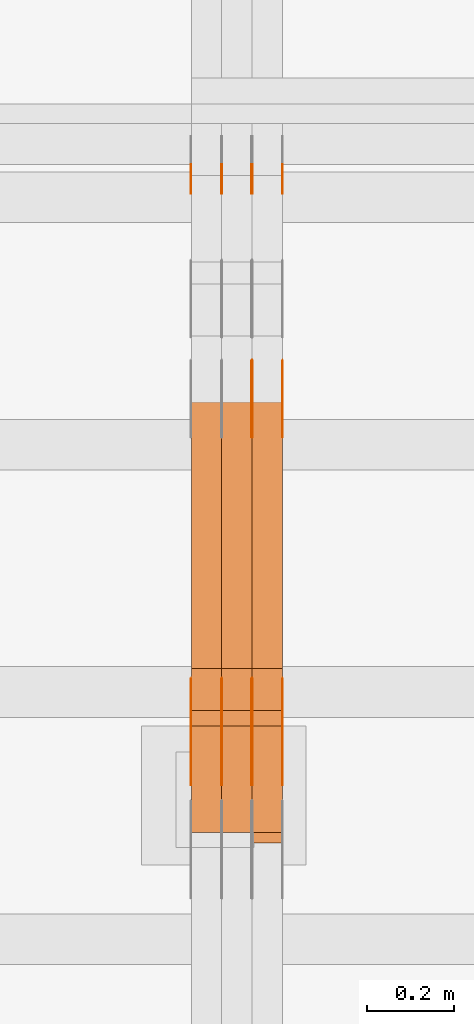
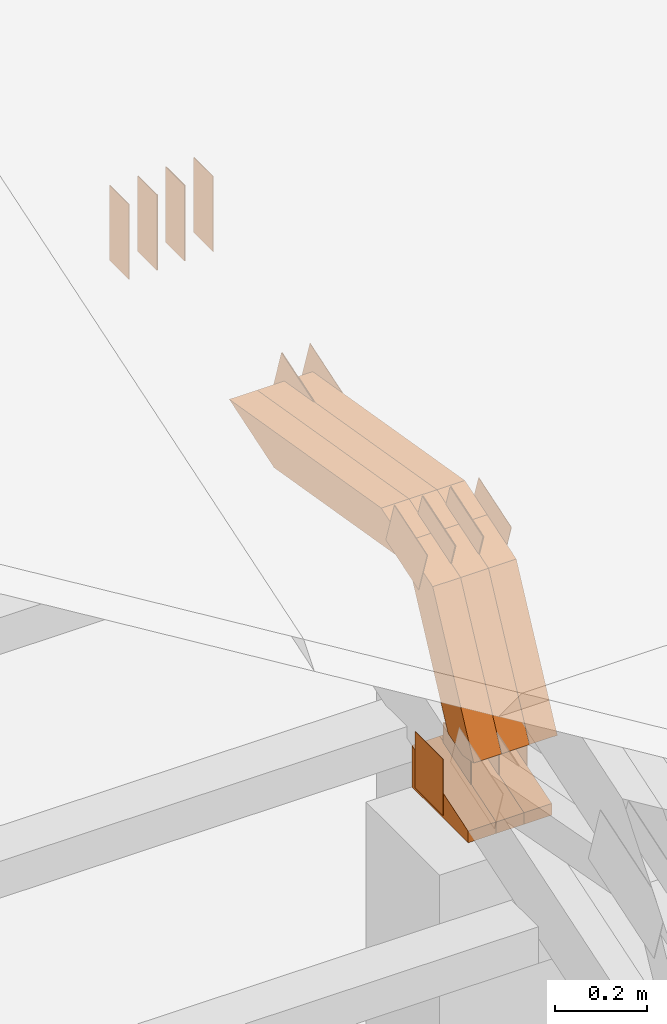
# One storey, part 159 of 385: 30 proxies.
"""IFC2X3 building model written with IfcOpenShell, lengths in millimetres."""

from ifc_helpers import new_model, entity, si_unit, converted_unit, derived_unit, direction, frame, frame_2d, origin, place, context, subcontext, project, spatial, polyline, rectangle, outline, extrude, source, transform, mapped, material, type_object, type_shapes, element, save


model = new_model("IFC2X3")

# Units and contexts
model_context = context("Model", 3, precision=0.01, world=origin(), true_north=direction((6.12303176911189e-17, 1.0)))
body_context = subcontext(model_context, "Body", "Model", "MODEL_VIEW")
ifc_project = project(units=[si_unit("LENGTHUNIT", "METRE", prefix="MILLI"), si_unit("AREAUNIT", "SQUARE_METRE"), si_unit("VOLUMEUNIT", "CUBIC_METRE"), converted_unit("PLANEANGLEUNIT", "DEGREE", entity("IfcRatioMeasure", 0.0174532925199433), si_unit("PLANEANGLEUNIT", "RADIAN"), dimensions=[0, 0, 0, 0, 0, 0, 0]), si_unit("MASSUNIT", "GRAM", prefix="KILO"), derived_unit("MASSDENSITYUNIT", [(si_unit("MASSUNIT", "GRAM", prefix="KILO"), 1), (si_unit("LENGTHUNIT", "METRE"), -3)]), si_unit("TIMEUNIT", "SECOND"), si_unit("FREQUENCYUNIT", "HERTZ"), si_unit("THERMODYNAMICTEMPERATUREUNIT", "DEGREE_CELSIUS"), derived_unit("THERMALTRANSMITTANCEUNIT", [(si_unit("MASSUNIT", "GRAM", prefix="KILO"), 1), (si_unit("THERMODYNAMICTEMPERATUREUNIT", "KELVIN"), -1), (si_unit("TIMEUNIT", "SECOND"), -3)]), derived_unit("VOLUMETRICFLOWRATEUNIT", [(si_unit("LENGTHUNIT", "METRE"), 3), (si_unit("TIMEUNIT", "SECOND"), -1)]), si_unit("ELECTRICCURRENTUNIT", "AMPERE"), si_unit("ELECTRICVOLTAGEUNIT", "VOLT"), si_unit("POWERUNIT", "WATT"), si_unit("FORCEUNIT", "NEWTON", prefix="KILO"), si_unit("ILLUMINANCEUNIT", "LUX"), si_unit("LUMINOUSFLUXUNIT", "LUMEN"), si_unit("LUMINOUSINTENSITYUNIT", "CANDELA"), derived_unit("USERDEFINED", [(si_unit("MASSUNIT", "GRAM", prefix="KILO"), -1), (si_unit("LENGTHUNIT", "METRE"), -2), (si_unit("TIMEUNIT", "SECOND"), 3), (si_unit("LUMINOUSFLUXUNIT", "LUMEN"), 1)]), derived_unit("LINEARVELOCITYUNIT", [(si_unit("LENGTHUNIT", "METRE"), 1), (si_unit("TIMEUNIT", "SECOND"), -1)]), si_unit("PRESSUREUNIT", "PASCAL"), derived_unit("USERDEFINED", [(si_unit("LENGTHUNIT", "METRE"), -2), (si_unit("MASSUNIT", "GRAM", prefix="KILO"), 1), (si_unit("TIMEUNIT", "SECOND"), -2)])], contexts=[model_context])

# Site, building, storey
site_placement = place(None, origin())
site = spatial("IfcSite", under=ifc_project, at=site_placement, CompositionType="ELEMENT")
building_placement = place(site_placement, origin())
building = spatial("IfcBuilding", under=site, at=building_placement, CompositionType="ELEMENT")
storey_placement = place(building_placement, origin())
storey = spatial("IfcBuildingStorey", under=building, at=storey_placement, Name="Default", CompositionType="ELEMENT", Elevation=0.0)

# Proxies
ifc_material_1 = material(Name="IfcSurfaceStyle #381300")
building_element_proxy_type_1 = type_object("IfcBuildingElementProxyType", PredefinedType="NOTDEFINED", material=ifc_material_1)
shared_shape_1 = source(origin(), body_context, "Body", "SweptSolid", [
    extrude(rectangle(XDim=200.0, YDim=84.0, at=frame_2d((0.0, -7.105427357601e-15), x_axis=(1.0, 0.0))), frame((100.0, 42.0, 0.0), z_axis=(0.0, 0.0, 1.0), x_axis=(-1.0, 0.0, 0.0)), (0.0, 0.0, 1.0), 1.3),
])
type_shapes(building_element_proxy_type_1, [shared_shape_1])
proxy_1_placement = place(building_placement, frame((30386.3, 13702.0, 3651.4150390625), z_axis=(-1.0, 0.0, 0.0), x_axis=(0.0, 0.0, -1.0)))
element("IfcBuildingElementProxy", 1, at=proxy_1_placement, inside=storey, type_object=building_element_proxy_type_1, material=ifc_material_1, context=body_context, shape_type="MappedRepresentation", body=[
    mapped(shared_shape_1, transform((0.0, 0.0, 0.0), scale=1.0)),
])
ifc_material_2 = material(Name="IfcSurfaceStyle #381243")
building_element_proxy_type_2 = type_object("IfcBuildingElementProxyType", PredefinedType="NOTDEFINED", material=ifc_material_2)
shared_shape_2 = source(origin(), body_context, "Body", "SweptSolid", [
    extrude(rectangle(XDim=200.0, YDim=84.0, at=frame_2d((0.0, -7.105427357601e-15), x_axis=(1.0, 0.0))), frame((100.0, 42.0, 0.0), z_axis=(0.0, 0.0, 1.0), x_axis=(-1.0, 0.0, 0.0)), (0.0, 0.0, 1.0), 1.3),
])
type_shapes(building_element_proxy_type_2, [shared_shape_2])
proxy_2_placement = place(building_placement, frame((30315.0, 13702.0, 3651.4150390625), z_axis=(-1.0, 0.0, 0.0), x_axis=(0.0, 0.0, -1.0)))
element("IfcBuildingElementProxy", 2, at=proxy_2_placement, inside=storey, type_object=building_element_proxy_type_2, material=ifc_material_2, context=body_context, shape_type="MappedRepresentation", body=[
    mapped(shared_shape_2, transform((0.0, 0.0, 0.0), scale=1.0)),
])
ifc_material_3 = material(Name="IfcSurfaceStyle #381186")
building_element_proxy_type_3 = type_object("IfcBuildingElementProxyType", PredefinedType="NOTDEFINED", material=ifc_material_3)
shared_shape_3 = source(origin(), body_context, "Body", "SweptSolid", [
    extrude(rectangle(XDim=200.0, YDim=84.0, at=frame_2d((0.0, -7.105427357601e-15), x_axis=(1.0, 0.0))), frame((100.0, 42.0, 0.0), z_axis=(0.0, 0.0, 1.0), x_axis=(-1.0, 0.0, 0.0)), (0.0, 0.0, 1.0), 1.3),
])
type_shapes(building_element_proxy_type_3, [shared_shape_3])
proxy_3_placement = place(building_placement, frame((30316.3, 13702.0, 3651.4150390625), z_axis=(-1.0, 0.0, 0.0), x_axis=(0.0, 0.0, -1.0)))
element("IfcBuildingElementProxy", 3, at=proxy_3_placement, inside=storey, type_object=building_element_proxy_type_3, material=ifc_material_3, context=body_context, shape_type="MappedRepresentation", body=[
    mapped(shared_shape_3, transform((0.0, 0.0, 0.0), scale=1.0)),
])
ifc_material_4 = material(Name="IfcSurfaceStyle #381129")
building_element_proxy_type_4 = type_object("IfcBuildingElementProxyType", PredefinedType="NOTDEFINED", material=ifc_material_4)
shared_shape_4 = source(origin(), body_context, "Body", "SweptSolid", [
    extrude(rectangle(XDim=200.0, YDim=84.0, at=frame_2d((0.0, -7.105427357601e-15), x_axis=(1.0, 0.0))), frame((100.0, 42.0, 0.0), z_axis=(0.0, 0.0, 1.0), x_axis=(-1.0, 0.0, 0.0)), (0.0, 0.0, 1.0), 1.29999999999998),
])
type_shapes(building_element_proxy_type_4, [shared_shape_4])
proxy_4_placement = place(building_placement, frame((30245.0, 13702.0, 3651.4150390625), z_axis=(-1.0, 0.0, 0.0), x_axis=(0.0, 0.0, -1.0)))
element("IfcBuildingElementProxy", 4, at=proxy_4_placement, inside=storey, type_object=building_element_proxy_type_4, material=ifc_material_4, context=body_context, shape_type="MappedRepresentation", body=[
    mapped(shared_shape_4, transform((0.0, 0.0, 0.0), scale=1.0)),
])
ifc_material_5 = material(Name="IfcSurfaceStyle #381072")
building_element_proxy_type_5 = type_object("IfcBuildingElementProxyType", PredefinedType="NOTDEFINED", material=ifc_material_5)
shared_shape_5 = source(origin(), body_context, "Body", "SweptSolid", [
    extrude(rectangle(XDim=200.0, YDim=84.0, at=frame_2d((0.0, -7.105427357601e-15), x_axis=(1.0, 0.0))), frame((100.0, 42.0, 0.0), z_axis=(0.0, 0.0, 1.0), x_axis=(-1.0, 0.0, 0.0)), (0.0, 0.0, 1.0), 1.29999999999998),
])
type_shapes(building_element_proxy_type_5, [shared_shape_5])
proxy_5_placement = place(building_placement, frame((30246.3, 13702.0, 3651.4150390625), z_axis=(-1.0, 0.0, 0.0), x_axis=(0.0, 0.0, -1.0)))
element("IfcBuildingElementProxy", 5, at=proxy_5_placement, inside=storey, type_object=building_element_proxy_type_5, material=ifc_material_5, context=body_context, shape_type="MappedRepresentation", body=[
    mapped(shared_shape_5, transform((0.0, 0.0, 0.0), scale=1.0)),
])
ifc_material_6 = material(Name="IfcSurfaceStyle #381015")
building_element_proxy_type_6 = type_object("IfcBuildingElementProxyType", PredefinedType="NOTDEFINED", material=ifc_material_6)
shared_shape_6 = source(origin(), body_context, "Body", "SweptSolid", [
    extrude(rectangle(XDim=200.0, YDim=84.0, at=frame_2d((0.0, -7.105427357601e-15), x_axis=(1.0, 0.0))), frame((100.0, 42.0, 0.0), z_axis=(0.0, 0.0, 1.0), x_axis=(-1.0, 0.0, 0.0)), (0.0, 0.0, 1.0), 1.29999999999999),
])
type_shapes(building_element_proxy_type_6, [shared_shape_6])
proxy_6_placement = place(building_placement, frame((30175.0, 13702.0, 3651.4150390625), z_axis=(-1.0, 0.0, 0.0), x_axis=(0.0, 0.0, -1.0)))
element("IfcBuildingElementProxy", 6, at=proxy_6_placement, inside=storey, type_object=building_element_proxy_type_6, material=ifc_material_6, context=body_context, shape_type="MappedRepresentation", body=[
    mapped(shared_shape_6, transform((0.0, 0.0, 0.0), scale=1.0)),
])
ifc_material_7 = material(Name="IfcSurfaceStyle #380958")
building_element_proxy_type_7 = type_object("IfcBuildingElementProxyType", PredefinedType="NOTDEFINED", material=ifc_material_7)
shared_shape_7 = source(origin(), body_context, "Body", "SweptSolid", [
    extrude(outline(polyline([(-75.0003398116828, -59.9998507501386), (75.0003249421766, -59.9998507501386), (75.0003398116837, 59.9998507501387), (-75.0003249421775, 59.9998507501387), (-75.0003398116828, -59.9998507501386)])), frame((75.0003398116837, 60.0000773549637, 0.0), z_axis=(0.0, 0.0, 1.0), x_axis=(-1.0, 0.0, 0.0)), (0.0, 0.0, 1.0), 1.3),
])
type_shapes(building_element_proxy_type_7, [shared_shape_7])
proxy_7_placement = place(building_placement, frame((30386.3, 13054.73046875, 3417.8388671875), z_axis=(-1.0, 0.0, 0.0), x_axis=(0.0, 0.951056516295124, 0.309016994375039)))
element("IfcBuildingElementProxy", 7, at=proxy_7_placement, inside=storey, type_object=building_element_proxy_type_7, material=ifc_material_7, context=body_context, shape_type="MappedRepresentation", body=[
    mapped(shared_shape_7, transform((0.0, 0.0, 0.0), scale=1.0)),
])
ifc_material_8 = material(Name="IfcSurfaceStyle #380901")
building_element_proxy_type_8 = type_object("IfcBuildingElementProxyType", PredefinedType="NOTDEFINED", material=ifc_material_8)
shared_shape_8 = source(origin(), body_context, "Body", "SweptSolid", [
    extrude(outline(polyline([(-75.0003398116828, -59.9998507501386), (75.0003249421766, -59.9998507501386), (75.0003398116837, 59.9998507501387), (-75.0003249421775, 59.9998507501387), (-75.0003398116828, -59.9998507501386)])), frame((75.0003398116837, 60.0000773549637, 0.0), z_axis=(0.0, 0.0, 1.0), x_axis=(-1.0, 0.0, 0.0)), (0.0, 0.0, 1.0), 1.3),
])
type_shapes(building_element_proxy_type_8, [shared_shape_8])
proxy_8_placement = place(building_placement, frame((30315.0, 13054.73046875, 3417.8388671875), z_axis=(-1.0, 0.0, 0.0), x_axis=(0.0, 0.951056516295124, 0.309016994375039)))
element("IfcBuildingElementProxy", 8, at=proxy_8_placement, inside=storey, type_object=building_element_proxy_type_8, material=ifc_material_8, context=body_context, shape_type="MappedRepresentation", body=[
    mapped(shared_shape_8, transform((0.0, 0.0, 0.0), scale=1.0)),
])
ifc_material_9 = material(Name="IfcSurfaceStyle #380844")
building_element_proxy_type_9 = type_object("IfcBuildingElementProxyType", PredefinedType="NOTDEFINED", material=ifc_material_9)
shared_shape_9 = source(origin(), body_context, "Body", "SweptSolid", [
    extrude(outline(polyline([(-75.0003398116828, -59.9998507501386), (75.0003249421766, -59.9998507501386), (75.0003398116837, 59.9998507501387), (-75.0003249421775, 59.9998507501387), (-75.0003398116828, -59.9998507501386)])), frame((75.0003398116837, 60.0000773549637, 0.0), z_axis=(0.0, 0.0, 1.0), x_axis=(-1.0, 0.0, 0.0)), (0.0, 0.0, 1.0), 1.3),
])
type_shapes(building_element_proxy_type_9, [shared_shape_9])
proxy_9_placement = place(building_placement, frame((30316.3, 13054.73046875, 3417.8388671875), z_axis=(-1.0, 0.0, 0.0), x_axis=(0.0, 0.951056516295124, 0.309016994375039)))
element("IfcBuildingElementProxy", 9, at=proxy_9_placement, inside=storey, type_object=building_element_proxy_type_9, material=ifc_material_9, context=body_context, shape_type="MappedRepresentation", body=[
    mapped(shared_shape_9, transform((0.0, 0.0, 0.0), scale=1.0)),
])
ifc_material_10 = material(Name="IfcSurfaceStyle #378906")
building_element_proxy_type_10 = type_object("IfcBuildingElementProxyType", PredefinedType="NOTDEFINED", material=ifc_material_10)
shared_shape_10 = source(origin(), body_context, "Body", "SweptSolid", [
    extrude(rectangle(XDim=150.0, YDim=119.999999999985, at=frame_2d((-7.105427357601e-15, 0.0), x_axis=(1.0, 0.0))), frame((75.0, 60.0, 0.0), z_axis=(0.0, 0.0, 1.0), x_axis=(-1.0, 0.0, 0.0)), (0.0, 0.0, 1.0), 1.3),
])
type_shapes(building_element_proxy_type_10, [shared_shape_10])
proxy_10_placement = place(building_placement, frame((30386.3, 12372.95703125, 3007.04687500001), z_axis=(-1.0, 0.0, 0.0), x_axis=(0.0, 0.0, -1.0)))
element("IfcBuildingElementProxy", 10, at=proxy_10_placement, inside=storey, type_object=building_element_proxy_type_10, material=ifc_material_10, context=body_context, shape_type="MappedRepresentation", body=[
    mapped(shared_shape_10, transform((0.0, 0.0, 0.0), scale=1.0)),
])
ifc_material_11 = material(Name="IfcSurfaceStyle #378849")
building_element_proxy_type_11 = type_object("IfcBuildingElementProxyType", PredefinedType="NOTDEFINED", material=ifc_material_11)
shared_shape_11 = source(origin(), body_context, "Body", "SweptSolid", [
    extrude(rectangle(XDim=150.0, YDim=119.999999999985, at=frame_2d((-7.105427357601e-15, 0.0), x_axis=(1.0, 0.0))), frame((75.0, 60.0, 0.0), z_axis=(0.0, 0.0, 1.0), x_axis=(-1.0, 0.0, 0.0)), (0.0, 0.0, 1.0), 1.3),
])
type_shapes(building_element_proxy_type_11, [shared_shape_11])
proxy_11_placement = place(building_placement, frame((30315.0, 12372.95703125, 3007.04687500001), z_axis=(-1.0, 0.0, 0.0), x_axis=(0.0, 0.0, -1.0)))
element("IfcBuildingElementProxy", 11, at=proxy_11_placement, inside=storey, type_object=building_element_proxy_type_11, material=ifc_material_11, context=body_context, shape_type="MappedRepresentation", body=[
    mapped(shared_shape_11, transform((0.0, 0.0, 0.0), scale=1.0)),
])
ifc_material_12 = material(Name="IfcSurfaceStyle #378792")
building_element_proxy_type_12 = type_object("IfcBuildingElementProxyType", PredefinedType="NOTDEFINED", material=ifc_material_12)
shared_shape_12 = source(origin(), body_context, "Body", "SweptSolid", [
    extrude(rectangle(XDim=150.0, YDim=119.999999999985, at=frame_2d((-7.105427357601e-15, 0.0), x_axis=(1.0, 0.0))), frame((75.0, 60.0, 0.0), z_axis=(0.0, 0.0, 1.0), x_axis=(-1.0, 0.0, 0.0)), (0.0, 0.0, 1.0), 1.3),
])
type_shapes(building_element_proxy_type_12, [shared_shape_12])
proxy_12_placement = place(building_placement, frame((30316.3, 12372.95703125, 3007.04687500001), z_axis=(-1.0, 0.0, 0.0), x_axis=(0.0, 0.0, -1.0)))
element("IfcBuildingElementProxy", 12, at=proxy_12_placement, inside=storey, type_object=building_element_proxy_type_12, material=ifc_material_12, context=body_context, shape_type="MappedRepresentation", body=[
    mapped(shared_shape_12, transform((0.0, 0.0, 0.0), scale=1.0)),
])
ifc_material_13 = material(Name="IfcSurfaceStyle #378735")
building_element_proxy_type_13 = type_object("IfcBuildingElementProxyType", PredefinedType="NOTDEFINED", material=ifc_material_13)
shared_shape_13 = source(origin(), body_context, "Body", "SweptSolid", [
    extrude(rectangle(XDim=150.0, YDim=119.999999999985, at=frame_2d((-7.105427357601e-15, 0.0), x_axis=(1.0, 0.0))), frame((75.0, 60.0, 0.0), z_axis=(0.0, 0.0, 1.0), x_axis=(-1.0, 0.0, 0.0)), (0.0, 0.0, 1.0), 1.29999999999999),
])
type_shapes(building_element_proxy_type_13, [shared_shape_13])
proxy_13_placement = place(building_placement, frame((30245.0, 12372.95703125, 3007.04687500001), z_axis=(-1.0, 0.0, 0.0), x_axis=(0.0, 0.0, -1.0)))
element("IfcBuildingElementProxy", 13, at=proxy_13_placement, inside=storey, type_object=building_element_proxy_type_13, material=ifc_material_13, context=body_context, shape_type="MappedRepresentation", body=[
    mapped(shared_shape_13, transform((0.0, 0.0, 0.0), scale=1.0)),
])
ifc_material_14 = material(Name="IfcSurfaceStyle #378678")
building_element_proxy_type_14 = type_object("IfcBuildingElementProxyType", PredefinedType="NOTDEFINED", material=ifc_material_14)
shared_shape_14 = source(origin(), body_context, "Body", "SweptSolid", [
    extrude(rectangle(XDim=150.0, YDim=119.999999999985, at=frame_2d((-7.105427357601e-15, 0.0), x_axis=(1.0, 0.0))), frame((75.0, 60.0, 0.0), z_axis=(0.0, 0.0, 1.0), x_axis=(-1.0, 0.0, 0.0)), (0.0, 0.0, 1.0), 1.29999999999999),
])
type_shapes(building_element_proxy_type_14, [shared_shape_14])
proxy_14_placement = place(building_placement, frame((30246.3, 12372.95703125, 3007.04687500001), z_axis=(-1.0, 0.0, 0.0), x_axis=(0.0, 0.0, -1.0)))
element("IfcBuildingElementProxy", 14, at=proxy_14_placement, inside=storey, type_object=building_element_proxy_type_14, material=ifc_material_14, context=body_context, shape_type="MappedRepresentation", body=[
    mapped(shared_shape_14, transform((0.0, 0.0, 0.0), scale=1.0)),
])
ifc_material_15 = material(Name="IfcSurfaceStyle #378621")
building_element_proxy_type_15 = type_object("IfcBuildingElementProxyType", PredefinedType="NOTDEFINED", material=ifc_material_15)
shared_shape_15 = source(origin(), body_context, "Body", "SweptSolid", [
    extrude(rectangle(XDim=150.0, YDim=119.999999999985, at=frame_2d((-7.105427357601e-15, 0.0), x_axis=(1.0, 0.0))), frame((75.0, 60.0, 0.0), z_axis=(0.0, 0.0, 1.0), x_axis=(-1.0, 0.0, 0.0)), (0.0, 0.0, 1.0), 1.29999999999999),
])
type_shapes(building_element_proxy_type_15, [shared_shape_15])
proxy_15_placement = place(building_placement, frame((30175.0, 12372.95703125, 3007.04687500001), z_axis=(-1.0, 0.0, 0.0), x_axis=(0.0, 0.0, -1.0)))
element("IfcBuildingElementProxy", 15, at=proxy_15_placement, inside=storey, type_object=building_element_proxy_type_15, material=ifc_material_15, context=body_context, shape_type="MappedRepresentation", body=[
    mapped(shared_shape_15, transform((0.0, 0.0, 0.0), scale=1.0)),
])
ifc_material_16 = material(Name="IfcSurfaceStyle #371724")
building_element_proxy_type_16 = type_object("IfcBuildingElementProxyType", PredefinedType="NOTDEFINED", material=ifc_material_16)
shared_shape_16 = source(origin(), body_context, "Body", "SweptSolid", [
    extrude(outline(polyline([(-74.9998754286244, -60.0000016373506), (74.9998605591063, -60.0000016373506), (74.9998754286244, 60.0000016373506), (-74.9998605591063, 60.0000016373506), (-74.9998754286244, -60.0000016373506)])), frame((74.9998754286244, 60.0000016373506, 0.0), z_axis=(0.0, 0.0, 1.0), x_axis=(-1.0, 0.0, 0.0)), (0.0, 0.0, 1.0), 1.3),
])
type_shapes(building_element_proxy_type_16, [shared_shape_16])
proxy_16_placement = place(building_placement, frame((30386.3, 12321.1620861463, 3506.17707344366), z_axis=(-1.0, 0.0, 0.0), x_axis=(0.0, 0.951056516295154, 0.309016994374948)))
element("IfcBuildingElementProxy", 16, at=proxy_16_placement, inside=storey, type_object=building_element_proxy_type_16, material=ifc_material_16, context=body_context, shape_type="MappedRepresentation", body=[
    mapped(shared_shape_16, transform((0.0, 0.0, 0.0), scale=1.0)),
])
ifc_material_17 = material(Name="IfcSurfaceStyle #371667")
building_element_proxy_type_17 = type_object("IfcBuildingElementProxyType", PredefinedType="NOTDEFINED", material=ifc_material_17)
shared_shape_17 = source(origin(), body_context, "Body", "SweptSolid", [
    extrude(outline(polyline([(-74.9998754286244, -60.0000016373506), (74.9998605591063, -60.0000016373506), (74.9998754286244, 60.0000016373506), (-74.9998605591063, 60.0000016373506), (-74.9998754286244, -60.0000016373506)])), frame((74.9998754286244, 60.0000016373506, 0.0), z_axis=(0.0, 0.0, 1.0), x_axis=(-1.0, 0.0, 0.0)), (0.0, 0.0, 1.0), 1.3),
])
type_shapes(building_element_proxy_type_17, [shared_shape_17])
proxy_17_placement = place(building_placement, frame((30315.0, 12321.1620861463, 3506.17707344366), z_axis=(-1.0, 0.0, 0.0), x_axis=(0.0, 0.951056516295154, 0.309016994374948)))
element("IfcBuildingElementProxy", 17, at=proxy_17_placement, inside=storey, type_object=building_element_proxy_type_17, material=ifc_material_17, context=body_context, shape_type="MappedRepresentation", body=[
    mapped(shared_shape_17, transform((0.0, 0.0, 0.0), scale=1.0)),
])
ifc_material_18 = material(Name="IfcSurfaceStyle #371610")
building_element_proxy_type_18 = type_object("IfcBuildingElementProxyType", PredefinedType="NOTDEFINED", material=ifc_material_18)
shared_shape_18 = source(origin(), body_context, "Body", "SweptSolid", [
    extrude(outline(polyline([(-74.9998754286244, -60.0000016373506), (74.9998605591063, -60.0000016373506), (74.9998754286244, 60.0000016373506), (-74.9998605591063, 60.0000016373506), (-74.9998754286244, -60.0000016373506)])), frame((74.9998754286244, 60.0000016373506, 0.0), z_axis=(0.0, 0.0, 1.0), x_axis=(-1.0, 0.0, 0.0)), (0.0, 0.0, 1.0), 1.3),
])
type_shapes(building_element_proxy_type_18, [shared_shape_18])
proxy_18_placement = place(building_placement, frame((30316.3, 12321.1620861463, 3506.17707344366), z_axis=(-1.0, 0.0, 0.0), x_axis=(0.0, 0.951056516295154, 0.309016994374948)))
element("IfcBuildingElementProxy", 18, at=proxy_18_placement, inside=storey, type_object=building_element_proxy_type_18, material=ifc_material_18, context=body_context, shape_type="MappedRepresentation", body=[
    mapped(shared_shape_18, transform((0.0, 0.0, 0.0), scale=1.0)),
])
ifc_material_19 = material(Name="IfcSurfaceStyle #371553")
building_element_proxy_type_19 = type_object("IfcBuildingElementProxyType", PredefinedType="NOTDEFINED", material=ifc_material_19)
shared_shape_19 = source(origin(), body_context, "Body", "SweptSolid", [
    extrude(outline(polyline([(-74.9998754286244, -60.0000016373506), (74.9998605591063, -60.0000016373506), (74.9998754286244, 60.0000016373506), (-74.9998605591063, 60.0000016373506), (-74.9998754286244, -60.0000016373506)])), frame((74.9998754286244, 60.0000016373506, 0.0), z_axis=(0.0, 0.0, 1.0), x_axis=(-1.0, 0.0, 0.0)), (0.0, 0.0, 1.0), 1.29999999999999),
])
type_shapes(building_element_proxy_type_19, [shared_shape_19])
proxy_19_placement = place(building_placement, frame((30245.0, 12321.1620861463, 3506.17707344366), z_axis=(-1.0, 0.0, 0.0), x_axis=(0.0, 0.951056516295154, 0.309016994374948)))
element("IfcBuildingElementProxy", 19, at=proxy_19_placement, inside=storey, type_object=building_element_proxy_type_19, material=ifc_material_19, context=body_context, shape_type="MappedRepresentation", body=[
    mapped(shared_shape_19, transform((0.0, 0.0, 0.0), scale=1.0)),
])
ifc_material_20 = material(Name="IfcSurfaceStyle #371496")
building_element_proxy_type_20 = type_object("IfcBuildingElementProxyType", PredefinedType="NOTDEFINED", material=ifc_material_20)
shared_shape_20 = source(origin(), body_context, "Body", "SweptSolid", [
    extrude(outline(polyline([(-74.9998754286244, -60.0000016373506), (74.9998605591063, -60.0000016373506), (74.9998754286244, 60.0000016373506), (-74.9998605591063, 60.0000016373506), (-74.9998754286244, -60.0000016373506)])), frame((74.9998754286244, 60.0000016373506, 0.0), z_axis=(0.0, 0.0, 1.0), x_axis=(-1.0, 0.0, 0.0)), (0.0, 0.0, 1.0), 1.29999999999999),
])
type_shapes(building_element_proxy_type_20, [shared_shape_20])
proxy_20_placement = place(building_placement, frame((30246.3, 12321.1620861463, 3506.17707344366), z_axis=(-1.0, 0.0, 0.0), x_axis=(0.0, 0.951056516295154, 0.309016994374948)))
element("IfcBuildingElementProxy", 20, at=proxy_20_placement, inside=storey, type_object=building_element_proxy_type_20, material=ifc_material_20, context=body_context, shape_type="MappedRepresentation", body=[
    mapped(shared_shape_20, transform((0.0, 0.0, 0.0), scale=1.0)),
])
ifc_material_21 = material(Name="IfcSurfaceStyle #371439")
building_element_proxy_type_21 = type_object("IfcBuildingElementProxyType", PredefinedType="NOTDEFINED", material=ifc_material_21)
shared_shape_21 = source(origin(), body_context, "Body", "SweptSolid", [
    extrude(outline(polyline([(-74.9998754286244, -60.0000016373506), (74.9998605591063, -60.0000016373506), (74.9998754286244, 60.0000016373506), (-74.9998605591063, 60.0000016373506), (-74.9998754286244, -60.0000016373506)])), frame((74.9998754286244, 60.0000016373506, 0.0), z_axis=(0.0, 0.0, 1.0), x_axis=(-1.0, 0.0, 0.0)), (0.0, 0.0, 1.0), 1.29999999999999),
])
type_shapes(building_element_proxy_type_21, [shared_shape_21])
proxy_21_placement = place(building_placement, frame((30175.0, 12321.1620861463, 3506.17707344366), z_axis=(-1.0, 0.0, 0.0), x_axis=(0.0, 0.951056516295154, 0.309016994374948)))
element("IfcBuildingElementProxy", 21, at=proxy_21_placement, inside=storey, type_object=building_element_proxy_type_21, material=ifc_material_21, context=body_context, shape_type="MappedRepresentation", body=[
    mapped(shared_shape_21, transform((0.0, 0.0, 0.0), scale=1.0)),
])
ifc_material_22 = material(Name="IfcSurfaceStyle #363264")
building_element_proxy_type_22 = type_object("IfcBuildingElementProxyType", Name="T1-E1 363262", PredefinedType="NOTDEFINED", material=ifc_material_22)
shared_shape_22 = source(origin(), body_context, "Body", "SweptSolid", [
    extrude(outline(polyline([(-75.1378173828004, -122.500000000005), (35.3350830078246, -122.500000000005), (35.3350830078004, 122.500000000005), (4.46765136717545, 122.500000000005), (-75.1378173828004, -122.500000000005)])), frame((35.3350830078246, 122.500000104877, 0.0), z_axis=(0.0, 0.0, 1.0), x_axis=(-1.0, 0.0, 0.0)), (0.0, 0.0, 1.0), 70.0),
])
type_shapes(building_element_proxy_type_22, [shared_shape_22])
proxy_22_placement = place(building_placement, frame((30385.0, 12145.0, 2849.54565429685), z_axis=(-1.0, 0.0, 0.0), x_axis=(0.0, 0.0, 1.0)))
element("IfcBuildingElementProxy", 22, at=proxy_22_placement, inside=storey, type_object=building_element_proxy_type_22, material=ifc_material_22, Name="T1-E1", context=body_context, shape_type="MappedRepresentation", body=[
    mapped(shared_shape_22, transform((0.0, 0.0, 0.0), scale=1.0)),
])
ifc_material_23 = material(Name="IfcSurfaceStyle #363207")
building_element_proxy_type_23 = type_object("IfcBuildingElementProxyType", Name="T1-E1 363205", PredefinedType="NOTDEFINED", material=ifc_material_23)
shared_shape_23 = source(origin(), body_context, "Body", "SweptSolid", [
    extrude(outline(polyline([(-75.1378173828004, -122.500000000005), (35.3350830078246, -122.500000000005), (35.3350830078004, 122.500000000005), (4.46765136717545, 122.500000000005), (-75.1378173828004, -122.500000000005)])), frame((35.3350830078246, 122.500000104877, 0.0), z_axis=(0.0, 0.0, 1.0), x_axis=(-1.0, 0.0, 0.0)), (0.0, 0.0, 1.0), 70.0),
])
type_shapes(building_element_proxy_type_23, [shared_shape_23])
proxy_23_placement = place(building_placement, frame((30315.0, 12145.0, 2849.54565429685), z_axis=(-1.0, 0.0, 0.0), x_axis=(0.0, 0.0, 1.0)))
element("IfcBuildingElementProxy", 23, at=proxy_23_placement, inside=storey, type_object=building_element_proxy_type_23, material=ifc_material_23, Name="T1-E1", context=body_context, shape_type="MappedRepresentation", body=[
    mapped(shared_shape_23, transform((0.0, 0.0, 0.0), scale=1.0)),
])
ifc_material_24 = material(Name="IfcSurfaceStyle #363150")
building_element_proxy_type_24 = type_object("IfcBuildingElementProxyType", Name="T1-E1 363148", PredefinedType="NOTDEFINED", material=ifc_material_24)
shared_shape_24 = source(origin(), body_context, "Body", "SweptSolid", [
    extrude(outline(polyline([(-75.1378173828004, -122.500000000005), (35.3350830078246, -122.500000000005), (35.3350830078004, 122.500000000005), (4.46765136717545, 122.500000000005), (-75.1378173828004, -122.500000000005)])), frame((35.3350830078246, 122.500000104877, 0.0), z_axis=(0.0, 0.0, 1.0), x_axis=(-1.0, 0.0, 0.0)), (0.0, 0.0, 1.0), 70.0),
])
type_shapes(building_element_proxy_type_24, [shared_shape_24])
proxy_24_placement = place(building_placement, frame((30245.0, 12145.0, 2849.54565429685), z_axis=(-1.0, 0.0, 0.0), x_axis=(0.0, 0.0, 1.0)))
element("IfcBuildingElementProxy", 24, at=proxy_24_placement, inside=storey, type_object=building_element_proxy_type_24, material=ifc_material_24, Name="T1-E1", context=body_context, shape_type="MappedRepresentation", body=[
    mapped(shared_shape_24, transform((0.0, 0.0, 0.0), scale=1.0)),
])
ifc_material_25 = material(Name="IfcSurfaceStyle #361536")
building_element_proxy_type_25 = type_object("IfcBuildingElementProxyType", Name="T1-W7 361534", PredefinedType="NOTDEFINED", material=ifc_material_25)
shared_shape_25 = source(origin(), body_context, "Body", "SweptSolid", [
    extrude(outline(polyline([(-296.174043820986, -47.5000676566704), (297.841254477443, -47.5000676566704), (283.518570346415, -7.10254316533821e-06), (192.674144473719, 47.500071207942), (-477.859925476591, 47.500071207942), (-296.174043820986, -47.5000676566704)])), frame((297.841254477443, 47.5000816097442, 0.0), z_axis=(0.0, 0.0, 1.0), x_axis=(-1.0, 0.0, 0.0)), (0.0, 0.0, 1.0), 70.0),
])
type_shapes(building_element_proxy_type_25, [shared_shape_25])
proxy_25_placement = place(building_placement, frame((30385.0, 12419.2991208897, 3526.2136755972), z_axis=(-1.0, 0.0, 0.0), x_axis=(0.0, 0.985983815111804, -0.166840991178939)))
element("IfcBuildingElementProxy", 25, at=proxy_25_placement, inside=storey, type_object=building_element_proxy_type_25, material=ifc_material_25, Name="T1-W7", context=body_context, shape_type="MappedRepresentation", body=[
    mapped(shared_shape_25, transform((0.0, 0.0, 0.0), scale=1.0)),
])
ifc_material_26 = material(Name="IfcSurfaceStyle #361470")
building_element_proxy_type_26 = type_object("IfcBuildingElementProxyType", Name="T1-W7 361468", PredefinedType="NOTDEFINED", material=ifc_material_26)
shared_shape_26 = source(origin(), body_context, "Body", "SweptSolid", [
    extrude(outline(polyline([(-296.174043820986, -47.5000676566704), (297.841254477443, -47.5000676566704), (283.518570346415, -7.10254316533821e-06), (192.674144473719, 47.500071207942), (-477.859925476591, 47.500071207942), (-296.174043820986, -47.5000676566704)])), frame((297.841254477443, 47.5000816097442, 0.0), z_axis=(0.0, 0.0, 1.0), x_axis=(-1.0, 0.0, 0.0)), (0.0, 0.0, 1.0), 70.0),
])
type_shapes(building_element_proxy_type_26, [shared_shape_26])
proxy_26_placement = place(building_placement, frame((30315.0, 12419.2991208897, 3526.2136755972), z_axis=(-1.0, 0.0, 0.0), x_axis=(0.0, 0.985983815111804, -0.166840991178939)))
element("IfcBuildingElementProxy", 26, at=proxy_26_placement, inside=storey, type_object=building_element_proxy_type_26, material=ifc_material_26, Name="T1-W7", context=body_context, shape_type="MappedRepresentation", body=[
    mapped(shared_shape_26, transform((0.0, 0.0, 0.0), scale=1.0)),
])
ifc_material_27 = material(Name="IfcSurfaceStyle #361404")
building_element_proxy_type_27 = type_object("IfcBuildingElementProxyType", Name="T1-W7 361402", PredefinedType="NOTDEFINED", material=ifc_material_27)
shared_shape_27 = source(origin(), body_context, "Body", "SweptSolid", [
    extrude(outline(polyline([(-296.174043820986, -47.5000676566704), (297.841254477443, -47.5000676566704), (283.518570346415, -7.10254316533821e-06), (192.674144473719, 47.500071207942), (-477.859925476591, 47.500071207942), (-296.174043820986, -47.5000676566704)])), frame((297.841254477443, 47.5000816097442, 0.0), z_axis=(0.0, 0.0, 1.0), x_axis=(-1.0, 0.0, 0.0)), (0.0, 0.0, 1.0), 70.0),
])
type_shapes(building_element_proxy_type_27, [shared_shape_27])
proxy_27_placement = place(building_placement, frame((30245.0, 12419.2991208897, 3526.2136755972), z_axis=(-1.0, 0.0, 0.0), x_axis=(0.0, 0.985983815111804, -0.166840991178939)))
element("IfcBuildingElementProxy", 27, at=proxy_27_placement, inside=storey, type_object=building_element_proxy_type_27, material=ifc_material_27, Name="T1-W7", context=body_context, shape_type="MappedRepresentation", body=[
    mapped(shared_shape_27, transform((0.0, 0.0, 0.0), scale=1.0)),
])
ifc_material_28 = material(Name="IfcSurfaceStyle #361140")
building_element_proxy_type_28 = type_object("IfcBuildingElementProxyType", Name="T1-W36 361138", PredefinedType="NOTDEFINED", material=ifc_material_28)
shared_shape_28 = source(origin(), body_context, "Body", "SweptSolid", [
    extrude(outline(polyline([(-300.714670922549, -47.4998881108849), (134.031527004269, -47.499888110885), (180.52054953879, -0.000136170977331764), (193.89900152221, 47.500563476126), (-207.736407142719, 47.4993489166213), (-300.714670922549, -47.4998881108849)])), frame((193.899145164686, 47.5001861375837, 0.0), z_axis=(0.0, 0.0, 1.0), x_axis=(-1.0, 3.02403492980632e-06, 0.0)), (0.0, 0.0, 1.0), 70.0),
])
type_shapes(building_element_proxy_type_28, [shared_shape_28])
proxy_28_placement = place(building_placement, frame((30385.0, 12120.5935627532, 3076.1128858536), z_axis=(-1.0, 0.0, 0.0), x_axis=(0.0, 0.444384650266842, 0.895836080210669)))
element("IfcBuildingElementProxy", 28, at=proxy_28_placement, inside=storey, type_object=building_element_proxy_type_28, material=ifc_material_28, Name="T1-W36", context=body_context, shape_type="MappedRepresentation", body=[
    mapped(shared_shape_28, transform((0.0, 0.0, 0.0), scale=1.0)),
])
ifc_material_29 = material(Name="IfcSurfaceStyle #361074")
building_element_proxy_type_29 = type_object("IfcBuildingElementProxyType", Name="T1-W36 361072", PredefinedType="NOTDEFINED", material=ifc_material_29)
shared_shape_29 = source(origin(), body_context, "Body", "SweptSolid", [
    extrude(outline(polyline([(-300.714670922549, -47.4998881108849), (134.031527004269, -47.499888110885), (180.52054953879, -0.000136170977331764), (193.89900152221, 47.500563476126), (-207.736407142719, 47.4993489166213), (-300.714670922549, -47.4998881108849)])), frame((193.899145164686, 47.5001861375837, 0.0), z_axis=(0.0, 0.0, 1.0), x_axis=(-1.0, 3.02403492980632e-06, 0.0)), (0.0, 0.0, 1.0), 70.0),
])
type_shapes(building_element_proxy_type_29, [shared_shape_29])
proxy_29_placement = place(building_placement, frame((30315.0, 12120.5935627532, 3076.1128858536), z_axis=(-1.0, 0.0, 0.0), x_axis=(0.0, 0.444384650266842, 0.895836080210669)))
element("IfcBuildingElementProxy", 29, at=proxy_29_placement, inside=storey, type_object=building_element_proxy_type_29, material=ifc_material_29, Name="T1-W36", context=body_context, shape_type="MappedRepresentation", body=[
    mapped(shared_shape_29, transform((0.0, 0.0, 0.0), scale=1.0)),
])
ifc_material_30 = material(Name="IfcSurfaceStyle #361008")
building_element_proxy_type_30 = type_object("IfcBuildingElementProxyType", Name="T1-W36 361006", PredefinedType="NOTDEFINED", material=ifc_material_30)
shared_shape_30 = source(origin(), body_context, "Body", "SweptSolid", [
    extrude(outline(polyline([(-300.714670922549, -47.4998881108849), (134.031527004269, -47.499888110885), (180.52054953879, -0.000136170977331764), (193.89900152221, 47.500563476126), (-207.736407142719, 47.4993489166213), (-300.714670922549, -47.4998881108849)])), frame((193.899145164686, 47.5001861375837, 0.0), z_axis=(0.0, 0.0, 1.0), x_axis=(-1.0, 3.02403492980632e-06, 0.0)), (0.0, 0.0, 1.0), 70.0),
])
type_shapes(building_element_proxy_type_30, [shared_shape_30])
proxy_30_placement = place(building_placement, frame((30245.0, 12120.5935627532, 3076.1128858536), z_axis=(-1.0, 0.0, 0.0), x_axis=(0.0, 0.444384650266842, 0.895836080210669)))
element("IfcBuildingElementProxy", 30, at=proxy_30_placement, inside=storey, type_object=building_element_proxy_type_30, material=ifc_material_30, Name="T1-W36", context=body_context, shape_type="MappedRepresentation", body=[
    mapped(shared_shape_30, transform((0.0, 0.0, 0.0), scale=1.0)),
])

save(model, "model.ifc")
